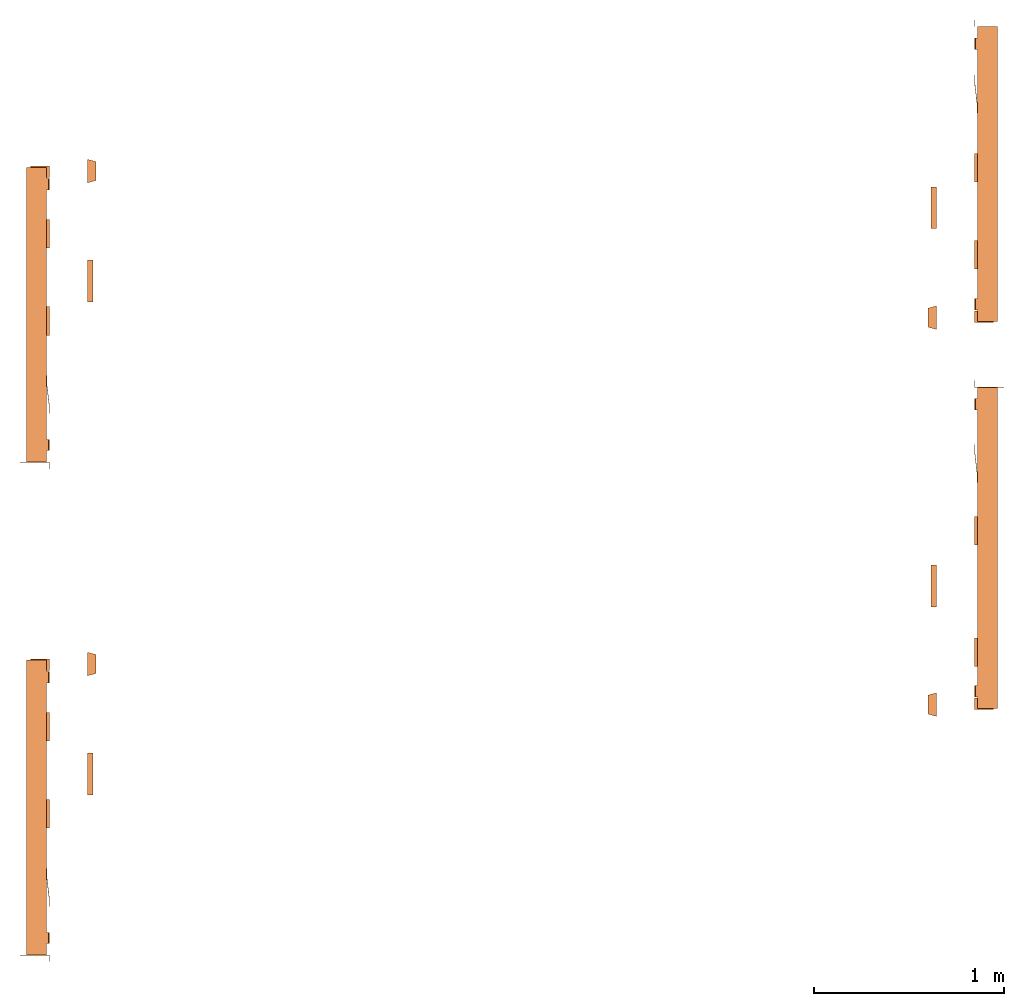
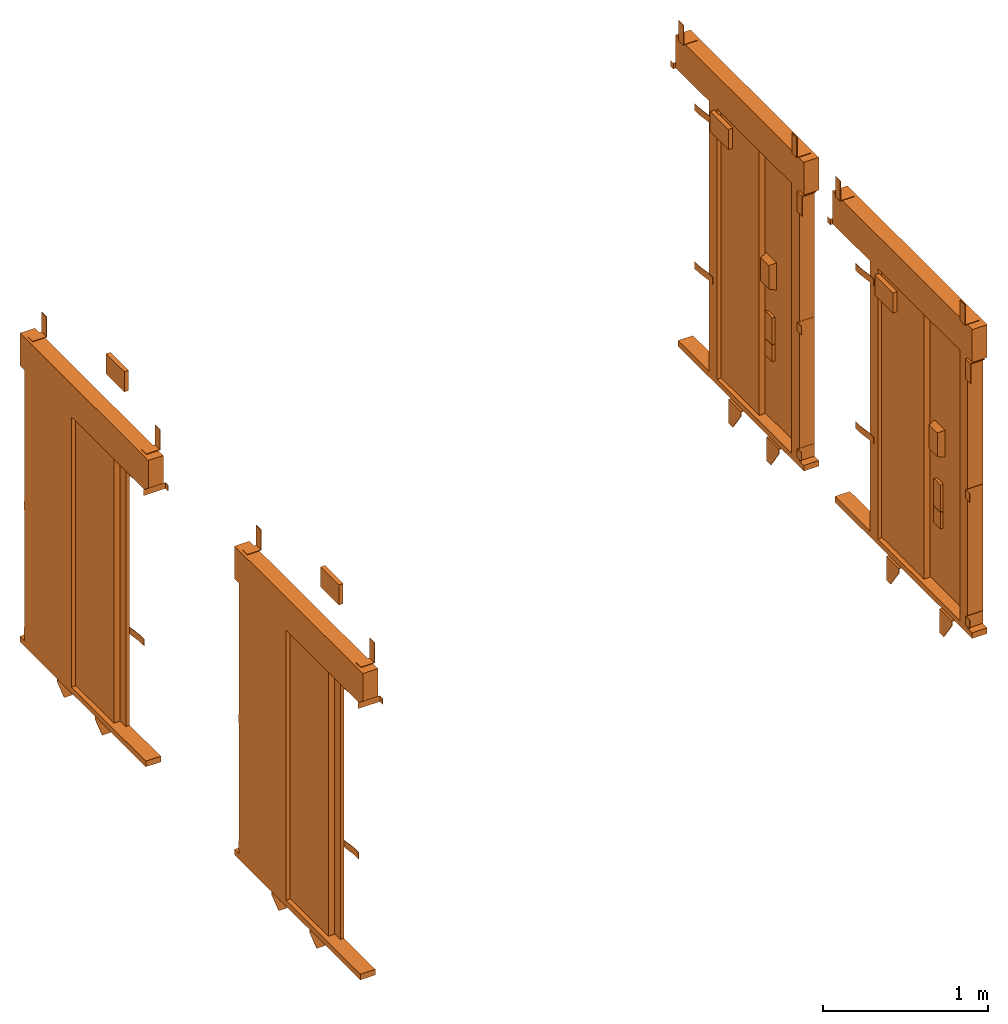
# One storey: 4 proxies.
"""IFC2X3 building model written with IfcOpenShell, lengths in millimetres."""

from ifc_helpers import new_model, entity, si_unit, converted_unit, derived_unit, direction, frame, origin, place, context, subcontext, project, spatial, faceted_brep, source, transform, mapped, material, type_object, type_shapes, element, save


model = new_model("IFC2X3")

# Units and contexts
model_context = context("Model", 3, precision=0.01, world=origin(), true_north=direction((6.12303176911189e-17, 1.0)))
body_context = subcontext(model_context, "Body", "Model", "MODEL_VIEW")
ifc_project = project(units=[si_unit("LENGTHUNIT", "METRE", prefix="MILLI"), si_unit("AREAUNIT", "SQUARE_METRE"), si_unit("VOLUMEUNIT", "CUBIC_METRE"), converted_unit("PLANEANGLEUNIT", "DEGREE", entity("IfcRatioMeasure", 0.0174532925199433), si_unit("PLANEANGLEUNIT", "RADIAN"), dimensions=[0, 0, 0, 0, 0, 0, 0]), si_unit("MASSUNIT", "GRAM", prefix="KILO"), derived_unit("MASSDENSITYUNIT", [(si_unit("MASSUNIT", "GRAM", prefix="KILO"), 1), (si_unit("LENGTHUNIT", "METRE"), -3)]), derived_unit("MOMENTOFINERTIAUNIT", [(si_unit("LENGTHUNIT", "METRE"), 4)]), si_unit("TIMEUNIT", "SECOND"), si_unit("FREQUENCYUNIT", "HERTZ"), si_unit("THERMODYNAMICTEMPERATUREUNIT", "DEGREE_CELSIUS"), derived_unit("THERMALTRANSMITTANCEUNIT", [(si_unit("MASSUNIT", "GRAM", prefix="KILO"), 1), (si_unit("THERMODYNAMICTEMPERATUREUNIT", "KELVIN"), -1), (si_unit("TIMEUNIT", "SECOND"), -3)]), derived_unit("VOLUMETRICFLOWRATEUNIT", [(si_unit("LENGTHUNIT", "METRE"), 3), (si_unit("TIMEUNIT", "SECOND"), -1)]), derived_unit("MASSFLOWRATEUNIT", [(si_unit("MASSUNIT", "GRAM", prefix="KILO"), 1), (si_unit("TIMEUNIT", "SECOND"), -1)]), derived_unit("ROTATIONALFREQUENCYUNIT", [(si_unit("TIMEUNIT", "SECOND"), -1)]), si_unit("ELECTRICCURRENTUNIT", "AMPERE"), si_unit("ELECTRICVOLTAGEUNIT", "VOLT"), si_unit("POWERUNIT", "WATT"), si_unit("FORCEUNIT", "NEWTON", prefix="KILO"), si_unit("ILLUMINANCEUNIT", "LUX"), si_unit("LUMINOUSFLUXUNIT", "LUMEN"), si_unit("LUMINOUSINTENSITYUNIT", "CANDELA"), derived_unit("USERDEFINED", [(si_unit("MASSUNIT", "GRAM", prefix="KILO"), -1), (si_unit("LENGTHUNIT", "METRE"), -2), (si_unit("TIMEUNIT", "SECOND"), 3), (si_unit("LUMINOUSFLUXUNIT", "LUMEN"), 1)]), derived_unit("LINEARVELOCITYUNIT", [(si_unit("LENGTHUNIT", "METRE"), 1), (si_unit("TIMEUNIT", "SECOND"), -1)]), si_unit("PRESSUREUNIT", "PASCAL"), derived_unit("USERDEFINED", [(si_unit("LENGTHUNIT", "METRE"), -2), (si_unit("MASSUNIT", "GRAM", prefix="KILO"), 1), (si_unit("TIMEUNIT", "SECOND"), -2)]), derived_unit("LINEARFORCEUNIT", [(si_unit("MASSUNIT", "GRAM", prefix="KILO"), 1), (si_unit("LENGTHUNIT", "METRE"), 1), (si_unit("TIMEUNIT", "SECOND"), -2), (si_unit("LENGTHUNIT", "METRE"), -1)]), derived_unit("PLANARFORCEUNIT", [(si_unit("MASSUNIT", "GRAM", prefix="KILO"), 1), (si_unit("LENGTHUNIT", "METRE"), 1), (si_unit("TIMEUNIT", "SECOND"), -2), (si_unit("LENGTHUNIT", "METRE"), -2)])], contexts=[model_context])

# Site, building, storey
site_placement = place(None, frame((0.0, -0.00077364408347762, 0.0)))
site = spatial("IfcSite", under=ifc_project, at=site_placement, CompositionType="ELEMENT")
building_placement = place(site_placement, origin())
building = spatial("IfcBuilding", under=site, at=building_placement, CompositionType="ELEMENT")
storey_placement = place(building_placement, frame((0.0, 0.0, 4200.0)))
storey = spatial("IfcBuildingStorey", under=building, at=storey_placement, CompositionType="ELEMENT", Elevation=4200.0)

# Proxies
ifc_material = material()
building_element_proxy_type_1 = type_object("IfcBuildingElementProxyType", PredefinedType="NOTDEFINED", material=ifc_material)
shared_shape_1 = source(origin(), body_context, "Body", "Brep", [
    faceted_brep([(-990.0, 1.5, 2038.5), (-990.0, 0.0, 2038.5), (-955.0, 0.0, 2038.5), (-955.0, 155.0, 2038.5), (-956.500000000089, 155.0, 2038.5), (-956.500000000089, 1.5, 2038.5), (-990.0, 1.5, 1995.5), (-956.500000000089, 1.5, 1995.5), (-956.500000000089, 155.0, 1995.5), (-955.0, 155.0, 1995.5), (-955.0, 0.0, 1995.5), (-990.0, 0.0, 1995.5)], [[[0, 1, 2, 3, 4, 5]], [[6, 7, 8, 9, 10, 11]], [[1, 0, 6, 11]], [[2, 1, 11, 10]], [[3, 2, 10, 9]], [[4, 3, 9, 8]], [[5, 4, 8, 7]], [[0, 5, 7, 6]]]),
    faceted_brep([(-699.0, 3.0, 1895.0), (-699.0, 0.0, 1895.0), (-649.0, 0.0, 1895.0), (-549.0, 12.0, 1895.0), (-499.0, 12.0, 1895.0), (-499.0, 15.0, 1895.0), (-549.0, 15.0, 1895.0), (-649.0, 3.0, 1895.0), (-699.0, 3.0, 1845.0), (-649.0, 3.0, 1845.0), (-549.0, 15.0, 1845.0), (-499.0, 15.0, 1845.0), (-499.0, 12.0, 1845.0), (-549.0, 12.0, 1845.0), (-649.0, 0.0, 1845.0), (-699.0, 0.0, 1845.0)], [[[0, 1, 2, 3, 4, 5, 6, 7]], [[8, 9, 10, 11, 12, 13, 14, 15]], [[1, 0, 8, 15]], [[2, 1, 15, 14]], [[3, 2, 14, 13]], [[4, 3, 13, 12]], [[5, 4, 12, 11]], [[6, 5, 11, 10]], [[7, 6, 10, 9]], [[0, 7, 9, 8]]]),
    faceted_brep([(-699.0, 3.0, 725.0), (-699.0, 0.0, 725.0), (-649.0, 0.0, 725.0), (-549.0, 12.0, 725.0), (-499.0, 12.0, 725.0), (-499.0, 15.0, 725.0), (-549.0, 15.0, 725.0), (-649.0, 3.0, 725.0), (-699.0, 3.0, 675.0), (-649.0, 3.0, 675.0), (-549.0, 15.0, 675.0), (-499.0, 15.0, 675.0), (-499.0, 12.0, 675.0), (-549.0, 12.0, 675.0), (-649.0, 0.0, 675.0), (-699.0, 0.0, 675.0)], [[[0, 1, 2, 3, 4, 5, 6, 7]], [[8, 9, 10, 11, 12, 13, 14, 15]], [[1, 0, 8, 15]], [[2, 1, 15, 14]], [[3, 2, 14, 13]], [[4, 3, 13, 12]], [[5, 4, 12, 11]], [[6, 5, 11, 10]], [[7, 6, 10, 9]], [[0, 7, 9, 8]]]),
    faceted_brep([(546.0, 121.0, 95.0), (546.0, 0.0, 95.0), (596.0, 0.0, 95.0), (596.0, 2.0, 95.0), (548.0, 2.0, 95.0), (548.0, 121.0, 95.0), (546.0, 121.0, 31.0), (548.0, 121.0, 31.0), (548.0, 2.0, 31.0), (596.0, 2.0, 31.0), (596.0, 0.0, 31.0), (546.0, 0.0, 31.0)], [[[0, 1, 2, 3, 4, 5]], [[6, 7, 8, 9, 10, 11]], [[1, 0, 6, 11]], [[2, 1, 11, 10]], [[3, 2, 10, 9]], [[4, 3, 9, 8]], [[5, 4, 8, 7]], [[0, 5, 7, 6]]]),
    faceted_brep([(546.0, 121.0, 1032.0), (546.0, 0.0, 1032.0), (596.0, 0.0, 1032.0), (596.0, 2.0, 1032.0), (548.0, 2.0, 1032.0), (548.0, 121.0, 1032.0), (546.0, 121.0, 968.0), (548.0, 121.0, 968.0), (548.0, 2.0, 968.0), (596.0, 2.0, 968.0), (596.0, 0.0, 968.0), (546.0, 0.0, 968.0)], [[[0, 1, 2, 3, 4, 5]], [[6, 7, 8, 9, 10, 11]], [[1, 0, 6, 11]], [[2, 1, 11, 10]], [[3, 2, 10, 9]], [[4, 3, 9, 8]], [[5, 4, 8, 7]], [[0, 5, 7, 6]]]),
    faceted_brep([(221.673343514568, 105.0, -47.0), (324.5, 33.0, -47.0), (324.5, 5.0, -47.0), (179.0, 5.0, -47.0), (179.0, 105.0, -47.0), (221.673343514568, 105.0, -42.0), (174.0, 105.0, -42.0), (174.0, 0.0, -42.0), (324.5, 0.0, -42.0), (324.5, 33.0, -42.0), (179.0, 105.0, -84.0), (174.0, 105.0, -84.0), (174.0, 55.8640183740593, -219.0), (174.0, 0.0, -219.0), (324.5, 0.0, -76.185199325789), (324.5, 5.0, -76.185199325789), (224.5, 5.0, -219.0), (179.0, 5.0, -219.0), (224.5, 0.0, -219.0), (179.0, 55.8640183740593, -219.0)], [[[0, 1, 2, 3, 4]], [[5, 6, 7, 8, 9]], [[6, 5, 0, 4, 10, 11]], [[6, 11, 12, 13, 7]], [[2, 1, 9, 8, 14, 15]], [[1, 0, 5, 9]], [[15, 16, 17, 3, 2]], [[7, 13, 18, 14, 8]], [[16, 15, 14, 18]], [[18, 13, 12, 19, 17, 16]], [[19, 10, 4, 3, 17]], [[12, 11, 10, 19]]]),
    faceted_brep([(-238.326656485432, 105.0, -47.0), (-135.5, 33.0, -47.0), (-135.5, 5.0, -47.0), (-281.0, 5.0, -47.0), (-281.0, 105.0, -47.0), (-238.326656485432, 105.0, -42.0), (-286.0, 105.0, -42.0), (-286.0, 0.0, -42.0), (-135.5, 0.0, -42.0), (-135.5, 33.0, -42.0), (-281.0, 105.0, -84.0), (-286.0, 105.0, -84.0), (-286.0, 55.864018374066, -219.0), (-286.0, 0.0, -219.0), (-135.5, 0.0, -76.185199325789), (-135.5, 5.0, -76.185199325789), (-235.5, 5.0, -219.0), (-281.0, 5.0, -219.0), (-235.5, 0.0, -219.0), (-281.0, 55.864018374066, -219.0)], [[[0, 1, 2, 3, 4]], [[5, 6, 7, 8, 9]], [[6, 5, 0, 4, 10, 11]], [[6, 11, 12, 13, 7]], [[2, 1, 9, 8, 14, 15]], [[1, 0, 5, 9]], [[15, 16, 17, 3, 2]], [[7, 13, 18, 14, 8]], [[16, 15, 14, 18]], [[18, 13, 12, 19, 17, 16]], [[19, 10, 4, 3, 17]], [[12, 11, 10, 19]]]),
    faceted_brep([(606.0, 100.0, 2000.0), (606.0, 0.0, 2000.0), (606.0, 0.0, 1850.0), (606.0, 4.0, 1850.0), (606.0, 4.0, 1996.0), (606.0, 100.0, 1996.0), (546.0, 100.0, 2000.0), (546.0, 100.0, 1996.0), (546.0, 4.0, 1996.0), (546.0, 4.0, 1850.0), (546.0, 0.0, 1850.0), (546.0, 0.0, 2000.0)], [[[0, 1, 2, 3, 4, 5]], [[6, 7, 8, 9, 10, 11]], [[1, 0, 6, 11]], [[2, 1, 11, 10]], [[3, 2, 10, 9]], [[4, 3, 9, 8]], [[5, 4, 8, 7]], [[0, 5, 7, 6]]]),
    faceted_brep([(540.0, 100.0, 2247.0), (540.0, 4.0, 2247.0), (540.0, 4.0, 2393.0), (540.0, 0.0, 2393.0), (540.0, 0.0, 2243.0), (540.0, 100.0, 2243.0), (480.0, 100.0, 2247.0), (480.0, 100.0, 2243.0), (480.0, 0.0, 2243.0), (480.0, 0.0, 2393.0), (480.0, 4.0, 2393.0), (480.0, 4.0, 2247.0)], [[[0, 1, 2, 3, 4, 5]], [[6, 7, 8, 9, 10, 11]], [[1, 0, 6, 11]], [[2, 1, 11, 10]], [[3, 2, 10, 9]], [[4, 3, 9, 8]], [[5, 4, 8, 7]], [[0, 5, 7, 6]]]),
    faceted_brep([(-835.0, 100.0, 2247.0), (-835.0, 4.0, 2247.0), (-835.0, 4.0, 2393.0), (-835.0, 0.0, 2393.0), (-835.0, 0.0, 2243.0), (-835.0, 100.0, 2243.0), (-895.0, 100.0, 2247.0), (-895.0, 100.0, 2243.0), (-895.0, 0.0, 2243.0), (-895.0, 0.0, 2393.0), (-895.0, 4.0, 2393.0), (-895.0, 4.0, 2247.0)], [[[0, 1, 2, 3, 4, 5]], [[6, 7, 8, 9, 10, 11]], [[1, 0, 6, 11]], [[2, 1, 11, 10]], [[3, 2, 10, 9]], [[4, 3, 9, 8]], [[5, 4, 8, 7]], [[0, 5, 7, 6]]]),
    faceted_brep([(630.0, -246.0, 1587.5), (530.0, -246.0, 1587.5), (530.0, -246.0, 1412.5), (630.0, -246.0, 1412.5), (642.500000000017, -200.0, 1600.0), (642.500000000017, -200.0, 1400.0), (517.500000000017, -200.0, 1400.0), (517.500000000017, -200.0, 1600.0)], [[[0, 1, 2, 3]], [[4, 5, 6, 7]], [[4, 7, 1, 0]], [[7, 6, 2, 1]], [[6, 5, 3, 2]], [[5, 4, 0, 3]]]),
    faceted_brep([(621.500000000017, -220.0, 985.0), (538.500000000017, -220.0, 985.0), (538.500000000017, -220.0, 862.0), (621.500000000017, -220.0, 862.0), (621.500000000017, -200.0, 985.0), (621.500000000017, -200.0, 862.0), (538.500000000017, -200.0, 862.0), (538.500000000017, -200.0, 985.0)], [[[0, 1, 2, 3]], [[4, 5, 6, 7]], [[1, 0, 4, 7]], [[2, 1, 7, 6]], [[3, 2, 6, 5]], [[0, 3, 5, 4]]]),
    faceted_brep([(110.0, -200.0, 2274.49999999999), (110.0, -200.0, 2125.49999999999), (-110.0, -200.0, 2125.49999999999), (-110.0, -200.0, 2274.49999999999), (110.0, -230.0, 2274.49999999999), (-110.0, -230.0, 2274.49999999999), (-110.0, -230.0, 2125.49999999999), (110.0, -230.0, 2125.49999999999)], [[[0, 1, 2, 3]], [[4, 5, 6, 7]], [[5, 4, 0, 3]], [[6, 5, 3, 2]], [[7, 6, 2, 1]], [[4, 7, 1, 0]]]),
    faceted_brep([(593.995794237314, -220.0, 1191.34563181984), (566.004205762722, -220.0, 1191.34563181984), (538.500000000018, -220.0, 1186.14489238263), (538.500000000017, -220.0, 989.0), (621.500000000016, -220.0, 989.0), (621.500000000017, -220.0, 1186.14489238263), (621.500000000016, -200.0, 1186.14489238263), (621.500000000016, -200.0, 989.0), (538.500000000017, -200.0, 989.0), (538.500000000019, -200.0, 1186.14489238263), (566.004205762722, -200.0, 1191.34563181984), (593.995794237314, -200.0, 1191.34563181984)], [[[0, 1, 2, 3, 4, 5]], [[6, 7, 8, 9, 10, 11]], [[3, 2, 9, 8]], [[4, 3, 8, 7]], [[5, 4, 7, 6]], [[6, 11, 0, 5]], [[11, 10, 1, 0]], [[10, 9, 2, 1]]]),
    faceted_brep([(450.0, 87.0, 2000.0), (450.0, 15.0, 2000.0), (546.0, 15.0, 2000.0), (546.0, 120.0, 2000.0), (469.0, 120.0, 2000.0), (469.0, 87.0, 2000.0), (450.0, 87.0, 0.0), (450.0, 15.0, 0.0), (546.0, 15.0, 0.0), (546.0, 120.0, 0.0), (469.0, 120.0, 0.0), (469.0, 87.0, 0.0)], [[[0, 1, 2, 3, 4, 5]], [[1, 0, 6, 7]], [[2, 1, 7, 8]], [[3, 2, 8, 9]], [[4, 3, 9, 10]], [[5, 4, 10, 11]], [[0, 5, 11, 6]], [[6, 11, 10, 9, 8, 7]]]),
    faceted_brep([(-450.0, 41.0, 0.0), (-450.0, 15.0, 0.0), (-546.0, 15.0, 0.0), (-546.0, 41.0, 0.0), (-546.0, 41.0, 2000.0), (-450.0, 41.0, 2000.0), (-546.0, 15.0, 2000.0), (-450.0, 15.0, 2000.0)], [[[0, 1, 2, 3]], [[4, 5, 0, 3]], [[6, 4, 3, 2]], [[7, 6, 2, 1]], [[5, 7, 1, 0]], [[5, 4, 6, 7]]]),
    faceted_brep([(600.0, 15.0, 0.0), (600.0, 15.0, -42.0), (600.0, 120.0, -42.0), (600.0, 120.0, 0.0), (-925.0, 15.0, 0.0), (-925.0, 120.0, 0.0), (-925.0, 120.0, -42.0), (-925.0, 15.0, -42.0)], [[[0, 1, 2, 3]], [[4, 5, 6, 7]], [[1, 0, 4, 7]], [[2, 1, 7, 6]], [[3, 2, 6, 5]], [[0, 3, 5, 4]]]),
    faceted_brep([(600.0, 15.0, 2243.0), (600.0, 15.0, 2000.0), (600.0, 120.0, 2000.0), (600.0, 120.0, 2243.0), (-955.0, 15.0, 2243.0), (-955.0, 120.0, 2243.0), (-955.0, 120.0, 2000.0), (-955.0, 15.0, 2000.0)], [[[0, 1, 2, 3]], [[4, 5, 6, 7]], [[1, 0, 4, 7]], [[2, 1, 7, 6]], [[3, 2, 6, 5]], [[0, 3, 5, 4]]]),
    faceted_brep([(465.0, 120.0, 2000.0), (-22.0, 120.0, 2000.0), (-22.0, 91.0, 2000.0), (465.0, 91.0, 2000.0), (465.0, 120.0, 0.0), (-22.0, 120.0, 0.0), (-22.0, 91.0, 0.0), (465.0, 91.0, 0.0)], [[[0, 1, 2, 3]], [[1, 0, 4, 5]], [[2, 1, 5, 6]], [[3, 2, 6, 7]], [[0, 3, 7, 4]], [[4, 7, 6, 5]]]),
    faceted_brep([(8.0, 87.0, 0.0), (8.0, 45.0, 0.0), (-480.0, 45.0, 0.0), (-480.0, 87.0, 0.0), (-480.0, 87.0, 2000.0), (8.0, 87.0, 2000.0), (-480.0, 45.0, 2000.0), (8.0, 45.0, 2000.0)], [[[0, 1, 2, 3]], [[4, 5, 0, 3]], [[6, 4, 3, 2]], [[7, 6, 2, 1]], [[5, 7, 1, 0]], [[5, 4, 6, 7]]]),
])
type_shapes(building_element_proxy_type_1, [shared_shape_1])
for number, where, z_axis, x_axis in (
    (1, (15840.0, 19312.1090833885, 0.0), (0.0, 0.0, 1.0), (0.0, -1.0, 0.0)),
    (2, (10959.8744854646, 16325.1547430131, 0.0), (0.0, 0.0, 1.0), (0.0, 1.0, 0.0)),
    (3, (10959.8744854646, 18925.1547430131, 0.0), (0.0, 0.0, 1.0), (0.0, 1.0, 0.0)),
):
    element("IfcBuildingElementProxy", number, at=place(storey_placement, frame(where, z_axis=z_axis, x_axis=x_axis)), inside=storey, type_object=building_element_proxy_type_1, material=ifc_material, context=body_context, shape_type="MappedRepresentation", body=[
        mapped(shared_shape_1, transform((0.0, 0.0, 0.0), scale=1.0)),
    ])
building_element_proxy_type_2 = type_object("IfcBuildingElementProxyType", PredefinedType="NOTDEFINED", material=ifc_material)
shared_shape_2 = source(origin(), body_context, "Body", "Brep", [
    faceted_brep([(-1082.3491109329, 1.5, 2038.5), (-1082.3491109329, 0.0, 2038.5), (-1047.3491109329, 0.0, 2038.5), (-1047.3491109329, 155.0, 2038.5), (-1048.8491109329, 155.0, 2038.5), (-1048.8491109329, 1.5, 2038.5), (-1082.3491109329, 1.5, 1995.5), (-1048.8491109329, 1.5, 1995.5), (-1048.8491109329, 155.0, 1995.5), (-1047.3491109329, 155.0, 1995.5), (-1047.3491109329, 0.0, 1995.5), (-1082.3491109329, 0.0, 1995.5)], [[[0, 1, 2, 3, 4, 5]], [[6, 7, 8, 9, 10, 11]], [[1, 0, 6, 11]], [[2, 1, 11, 10]], [[3, 2, 10, 9]], [[4, 3, 9, 8]], [[5, 4, 8, 7]], [[0, 5, 7, 6]]]),
    faceted_brep([(-745.174555466411, 3.0, 1895.0), (-745.174555466411, 0.0, 1895.0), (-695.174555466412, 0.0, 1895.0), (-595.174555466411, 12.0, 1895.0), (-545.174555466411, 12.0, 1895.0), (-545.174555466411, 15.0, 1895.0), (-595.174555466409, 15.0, 1895.0), (-695.174555466411, 3.0, 1895.0), (-745.174555466411, 3.0, 1845.0), (-695.174555466411, 3.0, 1845.0), (-595.174555466409, 15.0, 1845.0), (-545.174555466411, 15.0, 1845.0), (-545.174555466411, 12.0, 1845.0), (-595.174555466411, 12.0, 1845.0), (-695.174555466412, 0.0, 1845.0), (-745.174555466411, 0.0, 1845.0)], [[[0, 1, 2, 3, 4, 5, 6, 7]], [[8, 9, 10, 11, 12, 13, 14, 15]], [[1, 0, 8, 15]], [[2, 1, 15, 14]], [[3, 2, 14, 13]], [[4, 3, 13, 12]], [[5, 4, 12, 11]], [[6, 5, 11, 10]], [[7, 6, 10, 9]], [[0, 7, 9, 8]]]),
    faceted_brep([(-745.174555466411, 3.0, 725.0), (-745.174555466411, 0.0, 725.0), (-695.174555466412, 0.0, 725.0), (-595.174555466411, 12.0, 725.0), (-545.174555466411, 12.0, 725.0), (-545.174555466411, 15.0, 725.0), (-595.174555466409, 15.0, 725.0), (-695.174555466411, 3.0, 725.0), (-745.174555466411, 3.0, 675.0), (-695.174555466411, 3.0, 675.0), (-595.174555466409, 15.0, 675.0), (-545.174555466411, 15.0, 675.0), (-545.174555466411, 12.0, 675.0), (-595.174555466411, 12.0, 675.0), (-695.174555466412, 0.0, 675.0), (-745.174555466411, 0.0, 675.0)], [[[0, 1, 2, 3, 4, 5, 6, 7]], [[8, 9, 10, 11, 12, 13, 14, 15]], [[1, 0, 8, 15]], [[2, 1, 15, 14]], [[3, 2, 14, 13]], [[4, 3, 13, 12]], [[5, 4, 12, 11]], [[6, 5, 11, 10]], [[7, 6, 10, 9]], [[0, 7, 9, 8]]]),
    faceted_brep([(592.174555466353, 121.0, 95.0), (592.174555466353, 0.0, 95.0), (642.174555466354, 0.0, 95.0), (642.174555466354, 2.0, 95.0), (594.174555466354, 2.0, 95.0), (594.174555466354, 121.0, 95.0), (592.174555466353, 121.0, 31.0), (594.174555466354, 121.0, 31.0), (594.174555466354, 2.0, 31.0), (642.174555466354, 2.0, 31.0), (642.174555466354, 0.0, 31.0), (592.174555466353, 0.0, 31.0)], [[[0, 1, 2, 3, 4, 5]], [[6, 7, 8, 9, 10, 11]], [[1, 0, 6, 11]], [[2, 1, 11, 10]], [[3, 2, 10, 9]], [[4, 3, 9, 8]], [[5, 4, 8, 7]], [[0, 5, 7, 6]]]),
    faceted_brep([(592.174555466353, 121.0, 1032.0), (592.174555466353, 0.0, 1032.0), (642.174555466354, 0.0, 1032.0), (642.174555466354, 2.0, 1032.0), (594.174555466354, 2.0, 1032.0), (594.174555466354, 121.0, 1032.0), (592.174555466353, 121.0, 968.0), (594.174555466354, 121.0, 968.0), (594.174555466354, 2.0, 968.0), (642.174555466354, 2.0, 968.0), (642.174555466354, 0.0, 968.0), (592.174555466353, 0.0, 968.0)], [[[0, 1, 2, 3, 4, 5]], [[6, 7, 8, 9, 10, 11]], [[1, 0, 6, 11]], [[2, 1, 11, 10]], [[3, 2, 10, 9]], [[4, 3, 9, 8]], [[5, 4, 8, 7]], [[0, 5, 7, 6]]]),
    faceted_brep([(322.847898980971, 105.0, -47.0), (425.674555466403, 33.0, -47.0), (425.674555466403, 5.0, -47.0), (280.174555466403, 5.0, -47.0), (280.174555466403, 105.0, -47.0), (322.847898980971, 105.0, -42.0), (275.174555466403, 105.0, -42.0), (275.174555466403, 0.0, -42.0), (425.674555466403, 0.0, -42.0), (425.674555466403, 33.0, -42.0), (280.174555466403, 105.0, -84.0), (275.174555466403, 105.0, -84.0), (275.174555466403, 55.8640183740593, -219.0), (275.174555466403, 0.0, -219.0), (425.674555466403, 0.0, -76.185199325789), (425.674555466403, 5.0, -76.185199325789), (325.674555466403, 5.0, -219.0), (280.174555466403, 5.0, -219.0), (325.674555466403, 0.0, -219.0), (280.174555466403, 55.8640183740593, -219.0)], [[[0, 1, 2, 3, 4]], [[5, 6, 7, 8, 9]], [[6, 5, 0, 4, 10, 11]], [[6, 11, 12, 13, 7]], [[2, 1, 9, 8, 14, 15]], [[1, 0, 5, 9]], [[15, 16, 17, 3, 2]], [[7, 13, 18, 14, 8]], [[16, 15, 14, 18]], [[18, 13, 12, 19, 17, 16]], [[19, 10, 4, 3, 17]], [[12, 11, 10, 19]]]),
    faceted_brep([(-319.501211951835, 105.0, -47.0), (-216.674555466403, 33.0, -47.0), (-216.674555466403, 5.0, -47.0), (-362.174555466403, 5.0, -47.0), (-362.174555466402, 105.0, -47.0), (-319.501211951835, 105.0, -42.0), (-367.174555466402, 105.0, -42.0), (-367.174555466403, 0.0, -42.0), (-216.674555466403, 0.0, -42.0), (-216.674555466403, 33.0, -42.0), (-362.174555466402, 105.0, -84.0), (-367.174555466402, 105.0, -84.0), (-367.174555466403, 55.864018374066, -219.0), (-367.174555466403, 0.0, -219.0), (-216.674555466403, 0.0, -76.185199325789), (-216.674555466403, 5.0, -76.185199325789), (-316.674555466403, 5.0, -219.0), (-362.174555466403, 5.0, -219.0), (-316.674555466403, 0.0, -219.0), (-362.174555466403, 55.864018374066, -219.0)], [[[0, 1, 2, 3, 4]], [[5, 6, 7, 8, 9]], [[6, 5, 0, 4, 10, 11]], [[6, 11, 12, 13, 7]], [[2, 1, 9, 8, 14, 15]], [[1, 0, 5, 9]], [[15, 16, 17, 3, 2]], [[7, 13, 18, 14, 8]], [[16, 15, 14, 18]], [[18, 13, 12, 19, 17, 16]], [[19, 10, 4, 3, 17]], [[12, 11, 10, 19]]]),
    faceted_brep([(652.174555466354, 100.0, 2000.0), (652.174555466354, 0.0, 2000.0), (652.174555466354, 0.0, 1850.0), (652.174555466354, 4.0, 1850.0), (652.174555466354, 4.0, 1996.0), (652.174555466354, 100.0, 1996.0), (592.174555466354, 100.0, 2000.0), (592.174555466354, 100.0, 1996.0), (592.174555466354, 4.0, 1996.0), (592.174555466354, 4.0, 1850.0), (592.174555466354, 0.0, 1850.0), (592.174555466354, 0.0, 2000.0)], [[[0, 1, 2, 3, 4, 5]], [[6, 7, 8, 9, 10, 11]], [[1, 0, 6, 11]], [[2, 1, 11, 10]], [[3, 2, 10, 9]], [[4, 3, 9, 8]], [[5, 4, 8, 7]], [[0, 5, 7, 6]]]),
    faceted_brep([(586.174555466365, 100.0, 2247.0), (586.174555466365, 4.0, 2247.0), (586.174555466365, 4.0, 2393.0), (586.174555466365, 0.0, 2393.0), (586.174555466365, 0.0, 2243.0), (586.174555466365, 100.0, 2243.0), (526.174555466365, 100.0, 2247.0), (526.174555466365, 100.0, 2243.0), (526.174555466365, 0.0, 2243.0), (526.174555466365, 0.0, 2393.0), (526.174555466365, 4.0, 2393.0), (526.174555466365, 4.0, 2247.0)], [[[0, 1, 2, 3, 4, 5]], [[6, 7, 8, 9, 10, 11]], [[1, 0, 6, 11]], [[2, 1, 11, 10]], [[3, 2, 10, 9]], [[4, 3, 9, 8]], [[5, 4, 8, 7]], [[0, 5, 7, 6]]]),
    faceted_brep([(-927.34911093292, 100.0, 2247.0), (-927.34911093292, 4.0, 2247.0), (-927.34911093292, 4.0, 2393.0), (-927.34911093292, 0.0, 2393.0), (-927.34911093292, 0.0, 2243.0), (-927.34911093292, 100.0, 2243.0), (-987.349110932919, 100.0, 2247.0), (-987.349110932919, 100.0, 2243.0), (-987.349110932919, 0.0, 2243.0), (-987.349110932919, 0.0, 2393.0), (-987.349110932919, 4.0, 2393.0), (-987.349110932919, 4.0, 2247.0)], [[[0, 1, 2, 3, 4, 5]], [[6, 7, 8, 9, 10, 11]], [[1, 0, 6, 11]], [[2, 1, 11, 10]], [[3, 2, 10, 9]], [[4, 3, 9, 8]], [[5, 4, 8, 7]], [[0, 5, 7, 6]]]),
    faceted_brep([(676.17455546642, -246.0, 1587.5), (576.17455546642, -246.0, 1587.5), (576.17455546642, -246.0, 1412.5), (676.17455546642, -246.0, 1412.5), (688.67455546642, -200.0, 1600.0), (688.67455546642, -200.0, 1400.0), (563.67455546642, -200.0, 1400.0), (563.67455546642, -200.0, 1600.0)], [[[0, 1, 2, 3]], [[4, 5, 6, 7]], [[4, 7, 1, 0]], [[7, 6, 2, 1]], [[6, 5, 3, 2]], [[5, 4, 0, 3]]]),
    faceted_brep([(667.67455546642, -220.0, 985.0), (584.67455546642, -220.0, 985.0), (584.67455546642, -220.0, 862.0), (667.67455546642, -220.0, 862.0), (667.67455546642, -200.0, 985.0), (667.67455546642, -200.0, 862.0), (584.67455546642, -200.0, 862.0), (584.67455546642, -200.0, 985.0)], [[[0, 1, 2, 3]], [[4, 5, 6, 7]], [[1, 0, 4, 7]], [[2, 1, 7, 6]], [[3, 2, 6, 5]], [[0, 3, 5, 4]]]),
    faceted_brep([(110.0, -200.0, 2274.49999999999), (110.0, -200.0, 2125.49999999999), (-110.0, -200.0, 2125.49999999999), (-110.0, -200.0, 2274.49999999999), (110.0, -230.0, 2274.49999999999), (-110.0, -230.0, 2274.49999999999), (-110.0, -230.0, 2125.49999999999), (110.0, -230.0, 2125.49999999999)], [[[0, 1, 2, 3]], [[4, 5, 6, 7]], [[5, 4, 0, 3]], [[6, 5, 3, 2]], [[7, 6, 2, 1]], [[4, 7, 1, 0]]]),
    faceted_brep([(640.170349703717, -220.0, 1191.34563181984), (612.178761229125, -220.0, 1191.34563181984), (584.67455546642, -220.0, 1186.14489238263), (584.67455546642, -220.0, 989.0), (667.674555466419, -220.0, 989.0), (667.67455546642, -220.0, 1186.14489238263), (667.674555466419, -200.0, 1186.14489238263), (667.674555466419, -200.0, 989.0), (584.67455546642, -200.0, 989.0), (584.674555466421, -200.0, 1186.14489238263), (612.178761229125, -200.0, 1191.34563181984), (640.170349703717, -200.0, 1191.34563181984)], [[[0, 1, 2, 3, 4, 5]], [[6, 7, 8, 9, 10, 11]], [[3, 2, 9, 8]], [[4, 3, 8, 7]], [[5, 4, 7, 6]], [[6, 11, 0, 5]], [[11, 10, 1, 0]], [[10, 9, 2, 1]]]),
    faceted_brep([(496.174555466403, 87.0, 2000.0), (496.174555466403, 15.0, 2000.0), (592.174555466353, 15.0, 2000.0), (592.174555466353, 120.0, 2000.0), (515.17455546639, 120.0, 2000.0), (515.17455546639, 87.0, 2000.0), (496.174555466403, 87.0, 0.0), (496.174555466403, 15.0, 0.0), (592.174555466353, 15.0, 0.0), (592.174555466353, 120.0, 0.0), (515.17455546639, 120.0, 0.0), (515.17455546639, 87.0, 0.0)], [[[0, 1, 2, 3, 4, 5]], [[1, 0, 6, 7]], [[2, 1, 7, 8]], [[3, 2, 8, 9]], [[4, 3, 9, 10]], [[5, 4, 10, 11]], [[0, 5, 11, 6]], [[6, 11, 10, 9, 8, 7]]]),
    faceted_brep([(-496.174555466403, 41.0, 0.0), (-496.174555466403, 15.0, 0.0), (-592.174555466411, 15.0, 0.0), (-592.174555466411, 41.0, 0.0), (-592.174555466411, 41.0, 2000.0), (-496.174555466403, 41.0, 2000.0), (-592.174555466411, 15.0, 2000.0), (-496.174555466403, 15.0, 2000.0)], [[[0, 1, 2, 3]], [[4, 5, 0, 3]], [[6, 4, 3, 2]], [[7, 6, 2, 1]], [[5, 7, 1, 0]], [[5, 4, 6, 7]]]),
    faceted_brep([(646.174555466371, 15.0, 0.0), (646.174555466371, 15.0, -42.0), (646.174555466371, 120.0, -42.0), (646.174555466371, 120.0, 0.0), (-1017.34911093268, 15.0, 0.0), (-1017.34911093268, 120.0, 0.0), (-1017.34911093268, 120.0, -42.0), (-1017.34911093268, 15.0, -42.0)], [[[0, 1, 2, 3]], [[4, 5, 6, 7]], [[1, 0, 4, 7]], [[2, 1, 7, 6]], [[3, 2, 6, 5]], [[0, 3, 5, 4]]]),
    faceted_brep([(646.174555466371, 15.0, 2243.0), (646.174555466371, 15.0, 2000.0), (646.174555466371, 120.0, 2000.0), (646.174555466371, 120.0, 2243.0), (-1047.3491109329, 15.0, 2243.0), (-1047.3491109329, 120.0, 2243.0), (-1047.3491109329, 120.0, 2000.0), (-1047.3491109329, 15.0, 2000.0)], [[[0, 1, 2, 3]], [[4, 5, 6, 7]], [[1, 0, 4, 7]], [[2, 1, 7, 6]], [[3, 2, 6, 5]], [[0, 3, 5, 4]]]),
    faceted_brep([(511.174555466392, 120.0, 2000.0), (-22.0, 120.0, 2000.0), (-22.0, 91.0, 2000.0), (511.174555466392, 91.0, 2000.0), (511.174555466392, 120.0, 0.0), (-22.0, 120.0, 0.0), (-22.0, 91.0, 0.0), (511.174555466392, 91.0, 0.0)], [[[0, 1, 2, 3]], [[1, 0, 4, 5]], [[2, 1, 5, 6]], [[3, 2, 6, 7]], [[0, 3, 7, 4]], [[4, 7, 6, 5]]]),
    faceted_brep([(8.0, 87.0, 0.0), (8.0, 45.0, 0.0), (-526.174555466415, 45.0, 0.0), (-526.174555466415, 87.0, 0.0), (-526.174555466415, 87.0, 2000.0), (8.0, 87.0, 2000.0), (-526.174555466415, 45.0, 2000.0), (8.0, 45.0, 2000.0)], [[[0, 1, 2, 3]], [[4, 5, 0, 3]], [[6, 4, 3, 2]], [[7, 6, 2, 1]], [[5, 7, 1, 0]], [[5, 4, 6, 7]]]),
])
type_shapes(building_element_proxy_type_2, [shared_shape_2])
proxy_placement = place(storey_placement, frame((15840.0, 17317.2634793471, 0.0), z_axis=(0.0, 0.0, 1.0), x_axis=(0.0, -1.0, 0.0)))
element("IfcBuildingElementProxy", 4, at=proxy_placement, inside=storey, type_object=building_element_proxy_type_2, material=ifc_material, context=body_context, shape_type="MappedRepresentation", body=[
    mapped(shared_shape_2, transform((0.0, 0.0, 0.0), scale=1.0)),
])

save(model, "model.ifc")
